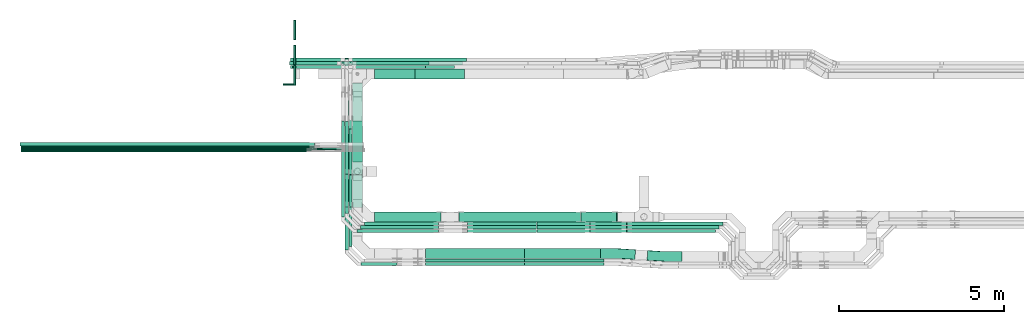
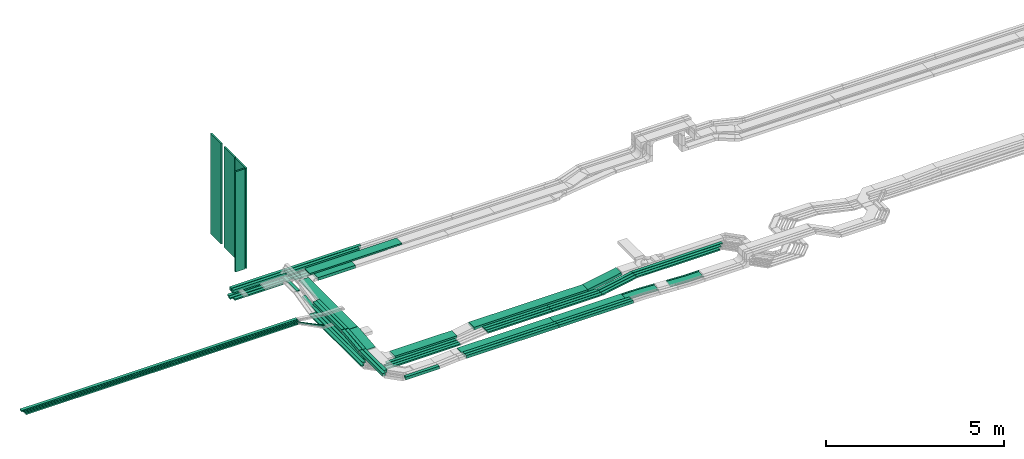
# One storey, part 1 of 32: 60 flow segments, 2 flow fittings.
"""IFC2X3 building model written with IfcOpenShell, lengths in millimetres."""

import ifcopenshell
import ifcopenshell.guid

model = None  # the IFC model being written
_history = None  # IfcOwnerHistory: only IFC2X3 demands one
_inside = {}  # id of a spatial element -> (the spatial element, [elements in it])
_under = {}  # id of a project, library or spatial element -> (it, [spatial elements below it])
_declared = {}  # id of a project -> (the project, [libraries it declares])
_typed = {}  # id of a type object -> (the type object, [elements of that type])
_made_of = {}  # id of a material, layer set ... -> (it, [elements and type objects made of it])


def new_model(schema):
    """Start an empty IFC model of exactly this schema.

    Asked for "IFC4X3", IfcOpenShell would pick the latest addendum, in which some entities
    have other attributes; the version numbers below select the first issue.
    IFC2X3 requires an IfcOwnerHistory on every rooted entity: one is made here for all.
    """
    global model, _history
    if schema == "IFC4X3":
        model = ifcopenshell.file(schema_version=(4, 3, 0, 0))
    else:
        model = ifcopenshell.file(schema=schema)
    _inside.clear()
    _under.clear()
    _declared.clear()
    _typed.clear()
    _made_of.clear()
    _history = None
    if model.schema == "IFC2X3":
        org = make("IfcOrganization", Name="unknown")
        user = make(
            "IfcPersonAndOrganization",
            ThePerson=make("IfcPerson", FamilyName="unknown"),
            TheOrganization=org,
        )
        app = make(
            "IfcApplication",
            ApplicationDeveloper=org,
            Version="unknown",
            ApplicationFullName="unknown",
            ApplicationIdentifier="unknown",
        )
        _history = make(
            "IfcOwnerHistory",
            OwningUser=user,
            OwningApplication=app,
            ChangeAction="ADDED",
            CreationDate=0,
        )
    return model


def make(cls, **values):
    """One entity of the class cls with the attributes given. An attribute that is None is left unset."""
    return model.create_entity(
        cls, **{name: value for name, value in values.items() if value is not None}
    )


def entity(cls, *values):
    """Any entity or typed value of the class cls, its attributes in the order of the schema. None: left unset."""
    e = model.create_entity(cls)
    for i, value in enumerate(values):
        if value is not None:
            e[i] = value
    return e


def rooted(cls, **values):
    """An entity with a GlobalId (a new one), such as an element, a storey or a relation."""
    return make(cls, GlobalId=ifcopenshell.guid.new(), OwnerHistory=_history, **values)


def si_unit(unit_type, name, prefix=None):
    """IfcSIUnit, for example si_unit("LENGTHUNIT", "METRE", prefix="MILLI")."""
    return make("IfcSIUnit", UnitType=unit_type, Prefix=prefix, Name=name)


def converted_unit(unit_type, name, factor, base, dimensions=None, offset=None):
    """IfcConversionBasedUnit, such as the inch: factor (a typed value) times the base unit."""
    return make(
        "IfcConversionBasedUnit"
        if offset is None
        else "IfcConversionBasedUnitWithOffset",
        ConversionOffset=offset,
        Dimensions=None
        if dimensions is None
        else entity("IfcDimensionalExponents", *dimensions),
        UnitType=unit_type,
        Name=name,
        ConversionFactor=make(
            "IfcMeasureWithUnit", ValueComponent=factor, UnitComponent=base
        ),
    )


def derived_unit(unit_type, elements):
    """IfcDerivedUnit: a product of units, each with its exponent."""
    return make(
        "IfcDerivedUnit",
        Elements=[
            make("IfcDerivedUnitElement", Unit=unit, Exponent=power)
            for unit, power in elements
        ],
        UnitType=unit_type,
    )


def assignment(units):
    """IfcUnitAssignment: the units of a project."""
    return None if units is None else make("IfcUnitAssignment", Units=units)


def point(xyz):
    """IfcCartesianPoint."""
    return None if xyz is None else make("IfcCartesianPoint", Coordinates=xyz)


def direction(xyz):
    """IfcDirection."""
    return None if xyz is None else make("IfcDirection", DirectionRatios=xyz)


def frame(location, z_axis=None, x_axis=None):
    """IfcAxis2Placement3D, a coordinate frame: its origin and axes. An axis left out is left unset."""
    return make(
        "IfcAxis2Placement3D",
        Location=point(location),
        Axis=direction(z_axis),
        RefDirection=direction(x_axis),
    )


def frame_2d(location, x_axis=None):
    """IfcAxis2Placement2D, a coordinate frame in the plane: its origin and x axis."""
    return make(
        "IfcAxis2Placement2D", Location=point(location), RefDirection=direction(x_axis)
    )


def origin():
    """The frame at (0, 0, 0) with its axes left unset."""
    return frame((0.0, 0.0, 0.0))


def origin_2d_with_axis():
    """The frame at (0, 0) in the plane with the x axis (1, 0) written out."""
    return frame_2d((0.0, 0.0), x_axis=(1.0, 0.0))


def place(relative_to, where):
    """IfcLocalPlacement: puts the frame where relative to a parent placement (None: the world)."""
    return make(
        "IfcLocalPlacement", PlacementRelTo=relative_to, RelativePlacement=where
    )


def context(
    kind, dimensions, precision=None, world=None, true_north=None, identifier=None
):
    """IfcGeometricRepresentationContext, for example the 3D "Model" context."""
    return make(
        "IfcGeometricRepresentationContext",
        ContextIdentifier=identifier,
        ContextType=kind,
        CoordinateSpaceDimension=dimensions,
        Precision=precision,
        WorldCoordinateSystem=world,
        TrueNorth=true_north,
    )


def subcontext(parent, identifier, kind, view, scale=None):
    """IfcGeometricRepresentationSubContext, for example "Body" below "Model"."""
    return make(
        "IfcGeometricRepresentationSubContext",
        ContextIdentifier=identifier,
        ContextType=kind,
        ParentContext=parent,
        TargetScale=scale,
        TargetView=view,
    )


def project(units=None, contexts=None):
    """IfcProject with its units and contexts."""
    return rooted(
        "IfcProject",
        Name="project",
        RepresentationContexts=contexts,
        UnitsInContext=assignment(units),
    )


def spatial(cls, under=None, at=None, **own):
    """A site, building, storey or space (cls), placed at a placement, below another one or the project."""
    s = rooted(cls, ObjectPlacement=at, **own)
    if under is not None:
        _under.setdefault(under.id(), (under, []))[1].append(s)
    return s


def profile(cls, at=None, kind="AREA", **sizes):
    """A parametric profile (cls). Its sizes go by their IFC names, for example OverallWidth=200.0."""
    return make(cls, ProfileType=kind, Position=at, **sizes)


def rectangle(**sizes):
    """IfcRectangleProfileDef."""
    return profile("IfcRectangleProfileDef", **sizes)


def extrude(swept, where, along, depth):
    """IfcExtrudedAreaSolid: the profile swept, set in the frame where, extruded along a direction by depth."""
    return make(
        "IfcExtrudedAreaSolid",
        SweptArea=swept,
        Position=where,
        ExtrudedDirection=direction(along),
        Depth=depth,
    )


def faces_of(points, faces, orient=None, outer=None):
    """IfcFace entities. A face is a list of loops; a loop is a list of indices into points, from 0.

    orient and outer hold one flag for each loop. By default every Orientation is true, the
    first loop of a face is its IfcFaceOuterBound and the others are IfcFaceBound.
    """
    made = []
    for i, loops in enumerate(faces):
        bounds = []
        for j, loop in enumerate(loops):
            is_outer = j == 0 if outer is None else outer[i][j]
            bounds.append(
                make(
                    "IfcFaceOuterBound" if is_outer else "IfcFaceBound",
                    Bound=make("IfcPolyLoop", Polygon=[points[k] for k in loop]),
                    Orientation=True if orient is None else orient[i][j],
                )
            )
        made.append(make("IfcFace", Bounds=bounds))
    return made


def faceted_brep(points, faces, orient=None, outer=None, voids=None):
    """IfcFacetedBrep: a solid bounded by flat faces; with voids (closed shells), ...WithVoids."""
    shared = [point(p) for p in points]
    hull = make("IfcClosedShell", CfsFaces=faces_of(shared, faces, orient, outer))
    if voids is None:
        return make("IfcFacetedBrep", Outer=hull)
    return make(
        "IfcFacetedBrepWithVoids",
        Outer=hull,
        Voids=[
            make(cls, CfsFaces=faces_of(shared, fs, o, b)) for cls, fs, o, b in voids
        ],
    )


def shape(context_of_items, identifier, shape_type, items):
    """IfcShapeRepresentation: the items that make up one representation, for example the "Body"."""
    return make(
        "IfcShapeRepresentation",
        ContextOfItems=context_of_items,
        RepresentationIdentifier=identifier,
        RepresentationType=shape_type,
        Items=items,
    )


def source(mapping_origin, context_of_items, identifier, shape_type, items):
    """IfcRepresentationMap: a shape defined once, which mapped items show again and again."""
    return make(
        "IfcRepresentationMap",
        MappingOrigin=mapping_origin,
        MappedRepresentation=shape(context_of_items, identifier, shape_type, items),
    )


def transform(
    local_origin,
    x_axis=None,
    y_axis=None,
    z_axis=None,
    scale=None,
    scale2=None,
    scale3=None,
    uniform=True,
):
    """IfcCartesianTransformationOperator3D, or its non-uniform kind. x_axis, y_axis, z_axis: its Axis1, 2, 3."""
    if uniform:
        return make(
            "IfcCartesianTransformationOperator3D",
            Axis1=direction(x_axis),
            Axis2=direction(y_axis),
            LocalOrigin=point(local_origin),
            Scale=scale,
            Axis3=direction(z_axis),
        )
    return make(
        "IfcCartesianTransformationOperator3DnonUniform",
        Axis1=direction(x_axis),
        Axis2=direction(y_axis),
        LocalOrigin=point(local_origin),
        Scale=scale,
        Axis3=direction(z_axis),
        Scale2=scale2,
        Scale3=scale3,
    )


def mapped(mapping_source, mapping_target):
    """IfcMappedItem: shows the shape of a source again, moved by a transform."""
    return make(
        "IfcMappedItem", MappingSource=mapping_source, MappingTarget=mapping_target
    )


def material(Name=None, Category=None):
    """IfcMaterial."""
    return make("IfcMaterial", Name=Name, Category=Category)


def made_of(thing, what):
    """Note that an element or type object is made of a material, layer set ...; save() writes the relation."""
    if what is not None:
        _made_of.setdefault(what.id(), (what, []))[1].append(thing)
    return thing


def type_object(cls, material=None, **own):
    """A type object (cls), such as IfcWallType, which elements share."""
    return made_of(rooted(cls, **own), material)


def type_shapes(of_type, sources):
    """Give a type object the sources (RepresentationMaps) that its elements show as mapped items."""
    of_type.RepresentationMaps = sources


def element(
    cls,
    number,
    at=None,
    inside=None,
    cuts=None,
    type_object=None,
    material=None,
    context=None,
    identifier="Body",
    shape_type=None,
    held_by="IfcProductDefinitionShape",
    body=None,
    shapes=None,
    **own,
):
    """One element of the class cls, such as IfcWall. Its Tag is "e" and its number.

    at: its placement. inside: the storey or other place that contains it. cuts: it is an
    opening in that element (IfcRelVoidsElement). A single representation is given by context,
    identifier, shape_type and body (its items); several are given by shapes. held_by: the class
    of the entity that holds the representations. save() writes the other relations.
    """
    e = rooted(cls, Tag="e%d" % number, ObjectPlacement=at, **own)
    if body is not None:
        shapes = [shape(context, identifier, shape_type, body)]
    if shapes is not None:
        e.Representation = make(held_by, Representations=shapes)
    if inside is not None:
        _inside.setdefault(inside.id(), (inside, []))[1].append(e)
    if cuts is not None:
        rooted(
            "IfcRelVoidsElement", RelatingBuildingElement=cuts, RelatedOpeningElement=e
        )
    if type_object is not None:
        _typed.setdefault(type_object.id(), (type_object, []))[1].append(e)
    return made_of(e, material)


def aggregate(whole, parts):
    """IfcRelAggregates: a whole, such as a stair, and the parts it consists of."""
    return rooted("IfcRelAggregates", RelatingObject=whole, RelatedObjects=parts)


def save(model, path):
    """Write the relations noted so far, then the file.

    IfcRelAggregates (storeys below a building ...), IfcRelContainedInSpatialStructure (elements
    in a storey), IfcRelDefinesByType, IfcRelAssociatesMaterial and IfcRelDeclares: one each for
    every whole, place, type object, material and project.
    """
    for whole, parts in _under.values():
        aggregate(whole, parts)
    for where, things in _inside.values():
        rooted(
            "IfcRelContainedInSpatialStructure",
            RelatedElements=things,
            RelatingStructure=where,
        )
    for kind, things in _typed.values():
        rooted("IfcRelDefinesByType", RelatedObjects=things, RelatingType=kind)
    for what, things in _made_of.values():
        rooted("IfcRelAssociatesMaterial", RelatedObjects=things, RelatingMaterial=what)
    for by, libraries in _declared.values():
        rooted("IfcRelDeclares", RelatingContext=by, RelatedDefinitions=libraries)
    model.write(path)


model = new_model("IFC2X3")

# Units and contexts
model_context = context("Model", 3, precision=0.01, world=origin(), true_north=direction((6.12303176911189e-17, 1.0)))
body_context = subcontext(model_context, "Body", "Model", "MODEL_VIEW")
ifc_project = project(units=[si_unit("LENGTHUNIT", "METRE", prefix="MILLI"), si_unit("AREAUNIT", "SQUARE_METRE"), si_unit("VOLUMEUNIT", "CUBIC_METRE"), converted_unit("PLANEANGLEUNIT", "DEGREE", entity("IfcRatioMeasure", 0.0174532925199433), si_unit("PLANEANGLEUNIT", "RADIAN"), dimensions=[0, 0, 0, 0, 0, 0, 0]), si_unit("MASSUNIT", "GRAM", prefix="KILO"), derived_unit("MASSDENSITYUNIT", [(si_unit("MASSUNIT", "GRAM", prefix="KILO"), 1), (si_unit("LENGTHUNIT", "METRE"), -3)]), derived_unit("MOMENTOFINERTIAUNIT", [(si_unit("LENGTHUNIT", "METRE"), 4)]), si_unit("TIMEUNIT", "SECOND"), si_unit("FREQUENCYUNIT", "HERTZ"), si_unit("THERMODYNAMICTEMPERATUREUNIT", "DEGREE_CELSIUS"), derived_unit("THERMALTRANSMITTANCEUNIT", [(si_unit("MASSUNIT", "GRAM", prefix="KILO"), 1), (si_unit("THERMODYNAMICTEMPERATUREUNIT", "KELVIN"), -1), (si_unit("TIMEUNIT", "SECOND"), -3)]), derived_unit("VOLUMETRICFLOWRATEUNIT", [(si_unit("LENGTHUNIT", "METRE"), 3), (si_unit("TIMEUNIT", "SECOND"), -1)]), derived_unit("MASSFLOWRATEUNIT", [(si_unit("MASSUNIT", "GRAM", prefix="KILO"), 1), (si_unit("TIMEUNIT", "SECOND"), -1)]), derived_unit("ROTATIONALFREQUENCYUNIT", [(si_unit("TIMEUNIT", "SECOND"), -1)]), si_unit("ELECTRICCURRENTUNIT", "AMPERE"), si_unit("ELECTRICVOLTAGEUNIT", "VOLT"), si_unit("POWERUNIT", "WATT"), si_unit("FORCEUNIT", "NEWTON", prefix="KILO"), si_unit("ILLUMINANCEUNIT", "LUX"), si_unit("LUMINOUSFLUXUNIT", "LUMEN"), si_unit("LUMINOUSINTENSITYUNIT", "CANDELA"), derived_unit("USERDEFINED", [(si_unit("MASSUNIT", "GRAM", prefix="KILO"), -1), (si_unit("LENGTHUNIT", "METRE"), -2), (si_unit("TIMEUNIT", "SECOND"), 3), (si_unit("LUMINOUSFLUXUNIT", "LUMEN"), 1)]), derived_unit("LINEARVELOCITYUNIT", [(si_unit("LENGTHUNIT", "METRE"), 1), (si_unit("TIMEUNIT", "SECOND"), -1)]), si_unit("PRESSUREUNIT", "PASCAL"), derived_unit("USERDEFINED", [(si_unit("LENGTHUNIT", "METRE"), -2), (si_unit("MASSUNIT", "GRAM", prefix="KILO"), 1), (si_unit("TIMEUNIT", "SECOND"), -2)]), derived_unit("LINEARFORCEUNIT", [(si_unit("MASSUNIT", "GRAM", prefix="KILO"), 1), (si_unit("LENGTHUNIT", "METRE"), 1), (si_unit("TIMEUNIT", "SECOND"), -2), (si_unit("LENGTHUNIT", "METRE"), -1)]), derived_unit("PLANARFORCEUNIT", [(si_unit("MASSUNIT", "GRAM", prefix="KILO"), 1), (si_unit("LENGTHUNIT", "METRE"), 1), (si_unit("TIMEUNIT", "SECOND"), -2), (si_unit("LENGTHUNIT", "METRE"), -2)])], contexts=[model_context])

# Site, building, storey
site_placement = place(None, origin())
site = spatial("IfcSite", under=ifc_project, at=site_placement, CompositionType="ELEMENT")
building_placement = place(site_placement, origin())
building = spatial("IfcBuilding", under=site, at=building_placement, CompositionType="ELEMENT")
storey_placement = place(building_placement, frame((0.0, 0.0, 8100.0)))
storey = spatial("IfcBuildingStorey", under=building, at=storey_placement, CompositionType="ELEMENT", Elevation=8100.0)

# Flow segments
cable_carrier_segment_type_1 = type_object("IfcCableCarrierSegmentType", PredefinedType="CABLETRAYSEGMENT")
flow_segment_1_placement = place(storey_placement, frame((18361.01, 14492.28, 2565.34)))
element("IfcFlowSegment", 1, at=flow_segment_1_placement, inside=storey, type_object=cable_carrier_segment_type_1, context=body_context, shape_type="SweptSolid", body=[
    extrude(rectangle(XDim=2981.2300000051, YDim=99.9999999999989, at=origin_2d_with_axis()), frame((1490.62, 50.0, 0.0)), (0.0, 0.0, 1.0), 50.0000000000016),
])
flow_segment_2_placement = place(storey_placement, frame((16421.3, 14492.28, 2565.34)))
element("IfcFlowSegment", 2, at=flow_segment_2_placement, inside=storey, type_object=cable_carrier_segment_type_1, context=body_context, shape_type="SweptSolid", body=[
    extrude(rectangle(XDim=1579.7076946329, YDim=99.9999999999989, at=origin_2d_with_axis()), frame((789.85, 50.0, 0.0), z_axis=(0.0, 0.0, 1.0), x_axis=(-1.0, 0.0, 0.0)), (0.0, 0.0, 1.0), 50.0000000000016),
])
flow_segment_3_placement = place(storey_placement, frame((16331.51, 14602.28, 2570.0)))
element("IfcFlowSegment", 3, at=flow_segment_3_placement, inside=storey, type_object=cable_carrier_segment_type_1, context=body_context, shape_type="SweptSolid", body=[
    extrude(rectangle(XDim=1629.50675573799, YDim=99.9999999999989, at=origin_2d_with_axis()), frame((814.75, 50.0, 0.0), z_axis=(0.0, 0.0, 1.0), x_axis=(-1.0, 0.0, 0.0)), (0.0, 0.0, 1.0), 50.0000000000016),
])
flow_segment_4_placement = place(storey_placement, frame((18676.05, 14182.28, 2840.02)))
element("IfcFlowSegment", 4, at=flow_segment_4_placement, inside=storey, type_object=cable_carrier_segment_type_1, context=body_context, shape_type="SweptSolid", body=[
    extrude(rectangle(XDim=2971.23000000509, YDim=300.000000000001, at=origin_2d_with_axis()), frame((1485.62, 150.0, 0.0)), (0.0, 0.0, 1.0), 50.0000000000016),
])
flow_segment_5_placement = place(storey_placement, frame((18076.05, 14492.28, 2840.0)))
element("IfcFlowSegment", 5, at=flow_segment_5_placement, inside=storey, type_object=cable_carrier_segment_type_1, context=body_context, shape_type="SweptSolid", body=[
    extrude(rectangle(XDim=2385.50742869904, YDim=99.9999999999989, at=origin_2d_with_axis()), frame((1192.75, 50.0, 0.0), z_axis=(0.0, 0.0, 1.0), x_axis=(-1.0, 0.0, 0.0)), (0.0, 0.0, 1.0), 99.9999999999989),
])
flow_segment_6_placement = place(storey_placement, frame((18186.05, 14602.28, 2840.0)))
element("IfcFlowSegment", 6, at=flow_segment_6_placement, inside=storey, type_object=cable_carrier_segment_type_1, context=body_context, shape_type="SweptSolid", body=[
    extrude(rectangle(XDim=2385.50742869902, YDim=99.9999999999989, at=origin_2d_with_axis()), frame((1192.75, 50.0, 0.0), z_axis=(0.0, 0.0, 1.0), x_axis=(-1.0, 0.0, 0.0)), (0.0, 0.0, 1.0), 99.9999999999989),
])
flow_segment_7_placement = place(storey_placement, frame((18922.05, 9845.0, 2500.0)))
element("IfcFlowSegment", 7, at=flow_segment_7_placement, inside=storey, type_object=cable_carrier_segment_type_1, context=body_context, shape_type="SweptSolid", body=[
    extrude(rectangle(XDim=2011.88022352649, YDim=300.000000000001, at=origin_2d_with_axis()), frame((1005.94, 150.0, 0.0)), (0.0, 0.0, 1.0), 99.9999999999989),
])
flow_segment_8_placement = place(storey_placement, frame((23464.79, 8622.45, 2789.67)))
element("IfcFlowSegment", 8, at=flow_segment_8_placement, inside=storey, type_object=cable_carrier_segment_type_1, context=body_context, shape_type="SweptSolid", body=[
    extrude(rectangle(XDim=2411.83602414101, YDim=100.000000000001, at=origin_2d_with_axis()), frame((1205.92, 50.0, 0.0)), (0.0, 0.0, 1.0), 99.9999999999989),
])
flow_segment_9_placement = place(storey_placement, frame((23462.62, 8732.05, 2790.02)))
element("IfcFlowSegment", 9, at=flow_segment_9_placement, inside=storey, type_object=cable_carrier_segment_type_1, context=body_context, shape_type="SweptSolid", body=[
    extrude(rectangle(XDim=2314.00000000008, YDim=299.999999999999, at=origin_2d_with_axis()), frame((1157.0, 150.0, 0.0)), (0.0, 0.0, 1.0), 50.0000000000016),
])
flow_segment_10_placement = place(storey_placement, frame((23468.94, 8512.45, 2789.32)))
element("IfcFlowSegment", 10, at=flow_segment_10_placement, inside=storey, type_object=cable_carrier_segment_type_1, context=body_context, shape_type="SweptSolid", body=[
    extrude(rectangle(XDim=2407.68395125738, YDim=99.9999999999989, at=origin_2d_with_axis()), frame((1203.84, 50.0, 0.0)), (0.0, 0.0, 1.0), 99.9999999999989),
])
flow_segment_11_placement = place(storey_placement, frame((18246.05, 11278.23, 2840.02)))
element("IfcFlowSegment", 11, at=flow_segment_11_placement, inside=storey, type_object=cable_carrier_segment_type_1, context=body_context, shape_type="SweptSolid", body=[
    extrude(rectangle(XDim=2774.04434845544, YDim=299.999999999997, at=origin_2d_with_axis()), frame((150.0, 1387.02, 0.0), z_axis=(0.0, -6.46277580620266e-07, 1.0), x_axis=(0.0, -1.0, -6.46277580620266e-07)), (0.0, 0.0, 1.0), 49.9999999999991),
])
flow_segment_12_placement = place(storey_placement, frame((18246.05, 11656.25, 2500.0)))
element("IfcFlowSegment", 12, at=flow_segment_12_placement, inside=storey, type_object=cable_carrier_segment_type_1, context=body_context, shape_type="SweptSolid", body=[
    extrude(rectangle(XDim=1245.36492297945, YDim=300.000000000001, at=origin_2d_with_axis()), frame((150.0, 622.68, 0.0), z_axis=(0.0, 0.0, 1.0), x_axis=(0.0, -1.0, 0.0)), (0.0, 0.0, 1.0), 99.9999999999989),
])
flow_segment_13_placement = place(storey_placement, frame((16359.58, 14712.28, 2570.0)))
element("IfcFlowSegment", 13, at=flow_segment_13_placement, inside=storey, type_object=cable_carrier_segment_type_1, context=body_context, shape_type="SweptSolid", body=[
    extrude(rectangle(XDim=1711.42940224653, YDim=99.9999999999989, at=origin_2d_with_axis()), frame((855.71, 50.0, 0.0), z_axis=(0.0, 0.0, 1.0), x_axis=(-1.0, 0.0, 0.0)), (0.0, 0.0, 1.0), 49.9999999999995),
])
flow_segment_14_placement = place(storey_placement, frame((23838.88, 9735.0, 2589.16)))
element("IfcFlowSegment", 14, at=flow_segment_14_placement, inside=storey, type_object=cable_carrier_segment_type_1, context=body_context, shape_type="SweptSolid", body=[
    extrude(rectangle(XDim=1615.92542255297, YDim=99.9999999999989, at=origin_2d_with_axis()), frame((807.96, 50.0, 0.0)), (0.0, 0.0, 1.0), 50.0000000000016),
])
flow_segment_15_placement = place(storey_placement, frame((23838.88, 9625.48, 2590.43)))
element("IfcFlowSegment", 15, at=flow_segment_15_placement, inside=storey, type_object=cable_carrier_segment_type_1, context=body_context, shape_type="SweptSolid", body=[
    extrude(rectangle(XDim=1615.94124469224, YDim=99.9999999999989, at=origin_2d_with_axis()), frame((807.97, 50.0, 0.0)), (0.0, 0.0, 1.0), 50.0000000000016),
])
flow_segment_16_placement = place(storey_placement, frame((23838.88, 9515.48, 2590.49)))
element("IfcFlowSegment", 16, at=flow_segment_16_placement, inside=storey, type_object=cable_carrier_segment_type_1, context=body_context, shape_type="SweptSolid", body=[
    extrude(rectangle(XDim=1615.94353988623, YDim=100.000000000001, at=origin_2d_with_axis()), frame((807.97, 50.0, 0.0)), (0.0, 0.0, 1.0), 50.0000000000016),
])
flow_segment_17_placement = place(storey_placement, frame((26574.44, 9735.0, 2800.0)))
element("IfcFlowSegment", 17, at=flow_segment_17_placement, inside=storey, type_object=cable_carrier_segment_type_1, context=body_context, shape_type="SweptSolid", body=[
    extrude(rectangle(XDim=2911.03097819719, YDim=99.9999999999989, at=origin_2d_with_axis()), frame((1455.52, 50.0, 0.0)), (0.0, 0.0, 1.0), 50.0000000000016),
])
flow_segment_18_placement = place(storey_placement, frame((26574.26, 9625.48, 2800.0)))
element("IfcFlowSegment", 18, at=flow_segment_18_placement, inside=storey, type_object=cable_carrier_segment_type_1, context=body_context, shape_type="SweptSolid", body=[
    extrude(rectangle(XDim=2801.68153191295, YDim=99.9999999999989, at=origin_2d_with_axis()), frame((1400.84, 50.0, 0.0)), (0.0, 0.0, 1.0), 50.0000000000016),
])
flow_segment_19_placement = place(storey_placement, frame((21484.25, 9845.0, 2595.02)))
element("IfcFlowSegment", 19, at=flow_segment_19_placement, inside=storey, type_object=cable_carrier_segment_type_1, context=body_context, shape_type="SweptSolid", body=[
    extrude(rectangle(XDim=3688.2870636457, YDim=300.000000000001, at=origin_2d_with_axis()), frame((1844.14, 150.0, 0.0)), (0.0, 0.0, 1.0), 99.9999999999989),
])
flow_segment_20_placement = place(storey_placement, frame((18502.05, 8512.45, 2739.32)))
element("IfcFlowSegment", 20, at=flow_segment_20_placement, inside=storey, type_object=cable_carrier_segment_type_1, context=body_context, shape_type="SweptSolid", body=[
    extrude(rectangle(XDim=1090.93059039301, YDim=100.000000000001, at=origin_2d_with_axis()), frame((545.47, 50.0, 0.0), z_axis=(0.0, 0.0, 1.0), x_axis=(-1.0, 0.0, 0.0)), (0.0, 0.0, 1.0), 100.000000000001),
])
flow_segment_21_placement = place(storey_placement, frame((8199.58, 12091.75, 3060.0)))
element("IfcFlowSegment", 21, at=flow_segment_21_placement, inside=storey, type_object=cable_carrier_segment_type_1, context=body_context, shape_type="SweptSolid", body=[
    extrude(rectangle(XDim=8897.16239513093, YDim=50.0000000000016, at=origin_2d_with_axis()), frame((4448.58, 25.0, 0.0), z_axis=(0.0, 0.0, 1.0), x_axis=(-1.0, 0.0, 0.0)), (0.0, 0.0, 1.0), 50.0000000000016),
])
flow_segment_22_placement = place(storey_placement, frame((18922.05, 14174.5, 2565.0)))
element("IfcFlowSegment", 22, at=flow_segment_22_placement, inside=storey, type_object=cable_carrier_segment_type_1, context=body_context, shape_type="SweptSolid", body=[
    extrude(rectangle(XDim=1223.84496020994, YDim=300.000000000001, at=origin_2d_with_axis()), frame((611.92, 150.0, 0.0), z_axis=(0.0, 0.0, 1.0), x_axis=(-1.0, 0.0, 0.0)), (0.0, 0.0, 1.0), 99.9999999999989),
])
flow_segment_23_placement = place(storey_placement, frame((20462.62, 8732.05, 2790.02)))
element("IfcFlowSegment", 23, at=flow_segment_23_placement, inside=storey, type_object=cable_carrier_segment_type_1, context=body_context, shape_type="SweptSolid", body=[
    extrude(rectangle(XDim=2997.46000001016, YDim=299.999999999999, at=origin_2d_with_axis()), frame((1498.73, 150.0, 0.0), z_axis=(0.0, 0.0, 1.0), x_axis=(-1.0, 0.0, 0.0)), (0.0, 0.0, 1.0), 50.0000000000016),
])
flow_segment_24_placement = place(storey_placement, frame((8199.58, 12031.75, 3060.0)))
element("IfcFlowSegment", 24, at=flow_segment_24_placement, inside=storey, type_object=cable_carrier_segment_type_1, context=body_context, shape_type="SweptSolid", body=[
    extrude(rectangle(XDim=8812.29056112652, YDim=50.0000000000016, at=origin_2d_with_axis()), frame((4406.15, 25.0, 0.0), z_axis=(0.0, 0.0, 1.0), x_axis=(-1.0, 0.0, 0.0)), (0.0, 0.0, 1.0), 50.0000000000016),
])
flow_segment_25_placement = place(storey_placement, frame((8199.58, 11971.75, 3060.0)))
element("IfcFlowSegment", 25, at=flow_segment_25_placement, inside=storey, type_object=cable_carrier_segment_type_1, context=body_context, shape_type="SweptSolid", body=[
    extrude(rectangle(XDim=8811.8645785195, YDim=50.0000000000016, at=origin_2d_with_axis()), frame((4405.93, 25.0, 0.0), z_axis=(0.0, 0.0, 1.0), x_axis=(-1.0, 0.0, 0.0)), (0.0, 0.0, 1.0), 50.0000000000016),
])
flow_segment_26_placement = place(storey_placement, frame((20464.79, 8622.45, 2789.67)))
element("IfcFlowSegment", 26, at=flow_segment_26_placement, inside=storey, type_object=cable_carrier_segment_type_1, context=body_context, shape_type="SweptSolid", body=[
    extrude(rectangle(XDim=2997.46000001016, YDim=100.000000000001, at=origin_2d_with_axis()), frame((1498.73, 50.0, 0.0), z_axis=(0.0, 0.0, 1.0), x_axis=(-1.0, 0.0, 0.0)), (0.0, 0.0, 1.0), 99.9999999999989),
])
flow_segment_27_placement = place(storey_placement, frame((20468.94, 8512.45, 2789.32)))
element("IfcFlowSegment", 27, at=flow_segment_27_placement, inside=storey, type_object=cable_carrier_segment_type_1, context=body_context, shape_type="SweptSolid", body=[
    extrude(rectangle(XDim=2997.46000001016, YDim=99.9999999999989, at=origin_2d_with_axis()), frame((1498.73, 50.0, 0.0), z_axis=(0.0, 0.0, 1.0), x_axis=(-1.0, 0.0, 0.0)), (0.0, 0.0, 1.0), 99.9999999999989),
])
flow_segment_28_placement = place(storey_placement, frame((8159.58, 12151.75, 3060.0)))
element("IfcFlowSegment", 28, at=flow_segment_28_placement, inside=storey, type_object=cable_carrier_segment_type_1, context=body_context, shape_type="SweptSolid", body=[
    extrude(rectangle(XDim=8936.98769079436, YDim=99.9999999999989, at=origin_2d_with_axis()), frame((4468.49, 50.0, 0.0), z_axis=(0.0, 0.0, 1.0), x_axis=(-1.0, 0.0, 0.0)), (0.0, 0.0, 1.0), 50.0000000000016),
])
flow_segment_29_placement = place(storey_placement, frame((18607.01, 9735.0, 2495.32)))
element("IfcFlowSegment", 29, at=flow_segment_29_placement, inside=storey, type_object=cable_carrier_segment_type_1, context=body_context, shape_type="SweptSolid", body=[
    extrude(rectangle(XDim=2253.98527272605, YDim=99.9999999999989, at=origin_2d_with_axis()), frame((1126.99, 50.0, 0.0), z_axis=(0.0, 0.0, 1.0), x_axis=(-1.0, 0.0, 0.0)), (0.0, 0.0, 1.0), 50.0000000000016),
])
flow_segment_30_placement = place(storey_placement, frame((18497.01, 9625.48, 2495.47)))
element("IfcFlowSegment", 30, at=flow_segment_30_placement, inside=storey, type_object=cable_carrier_segment_type_1, context=body_context, shape_type="SweptSolid", body=[
    extrude(rectangle(XDim=2363.95663058173, YDim=99.9999999999989, at=origin_2d_with_axis()), frame((1181.98, 50.0, 0.0), z_axis=(0.0, 0.0, 1.0), x_axis=(-1.0, 0.0, 0.0)), (0.0, 0.0, 1.0), 50.0000000000016),
])
flow_segment_31_placement = place(storey_placement, frame((18387.01, 9515.48, 2500.0)))
element("IfcFlowSegment", 31, at=flow_segment_31_placement, inside=storey, type_object=cable_carrier_segment_type_1, context=body_context, shape_type="SweptSolid", body=[
    extrude(rectangle(XDim=2473.54052636319, YDim=100.000000000001, at=origin_2d_with_axis()), frame((1236.77, 50.0, 0.0), z_axis=(0.0, 0.0, 1.0), x_axis=(-1.0, 0.0, 0.0)), (0.0, 0.0, 1.0), 50.0000000000016),
])
flow_segment_32_placement = place(storey_placement, frame((18131.01, 12665.28, 2495.52)))
element("IfcFlowSegment", 32, at=flow_segment_32_placement, inside=storey, type_object=cable_carrier_segment_type_1, context=body_context, shape_type="SweptSolid", body=[
    extrude(rectangle(XDim=49.9999999999999, YDim=1019.51076030492, at=frame_2d((0.0, 0.0), x_axis=(0.0, 1.0))), frame((0.0, 510.27, 59.82), z_axis=(1.0, 0.0, 0.0), x_axis=(0.0, 0.997656992775831, 0.0684143608132536)), (0.0, 0.0, 1.0), 99.9999999999989),
])
flow_segment_33_placement = place(storey_placement, frame((18021.01, 13788.82, 2710.72)))
element("IfcFlowSegment", 33, at=flow_segment_33_placement, inside=storey, type_object=cable_carrier_segment_type_1, context=body_context, shape_type="SweptSolid", body=[
    extrude(rectangle(XDim=1004.45523850221, YDim=99.9999999999989, at=origin_2d_with_axis()), frame((50.0, 502.23, 0.0), z_axis=(0.0, 0.0, 1.0), x_axis=(0.0, 1.0, 0.0)), (0.0, 0.0, 1.0), 50.0000000000038),
])
flow_segment_34_placement = place(storey_placement, frame((18072.01, 14712.28, 2570.0)))
element("IfcFlowSegment", 34, at=flow_segment_34_placement, inside=storey, type_object=cable_carrier_segment_type_1, context=body_context, shape_type="SweptSolid", body=[
    extrude(rectangle(XDim=3635.06094064414, YDim=99.9999999999989, at=origin_2d_with_axis()), frame((1817.53, 50.0, 0.0), z_axis=(0.0, 0.0, 1.0), x_axis=(-1.0, 0.0, 0.0)), (0.0, 0.0, 1.0), 50.0000000000016),
])
flow_segment_35_placement = place(storey_placement, frame((17962.01, 14602.28, 2570.0)))
element("IfcFlowSegment", 35, at=flow_segment_35_placement, inside=storey, type_object=cable_carrier_segment_type_1, context=body_context, shape_type="SweptSolid", body=[
    extrude(rectangle(XDim=3629.49324426201, YDim=99.9999999999989, at=origin_2d_with_axis()), frame((1814.75, 50.0, 0.0), z_axis=(0.0, 0.0, 1.0), x_axis=(-1.0, 0.0, 0.0)), (0.0, 0.0, 1.0), 50.0000000000016),
])
flow_segment_36_placement = place(storey_placement, frame((18136.05, 11279.53, 2840.0)))
element("IfcFlowSegment", 36, at=flow_segment_36_placement, inside=storey, type_object=cable_carrier_segment_type_1, context=body_context, shape_type="SweptSolid", body=[
    extrude(rectangle(XDim=1630.30438948267, YDim=99.9999999999989, at=origin_2d_with_axis()), frame((50.0, 815.15, 0.0), z_axis=(0.0, 0.0, 1.0), x_axis=(0.0, 1.0, 0.0)), (0.0, 0.0, 1.0), 99.9999999999989),
])
flow_segment_37_placement = place(storey_placement, frame((18026.05, 11299.51, 2840.0)))
element("IfcFlowSegment", 37, at=flow_segment_37_placement, inside=storey, type_object=cable_carrier_segment_type_1, context=body_context, shape_type="SweptSolid", body=[
    extrude(rectangle(XDim=1589.99978553911, YDim=99.9999999999989, at=origin_2d_with_axis()), frame((50.0, 795.0, 0.0), z_axis=(0.0, 0.0, 1.0), x_axis=(0.0, 1.0, 0.0)), (0.0, 0.0, 1.0), 99.9999999999989),
])
flow_segment_38_placement = place(storey_placement, frame((18136.05, 9098.45, 2739.54)))
element("IfcFlowSegment", 38, at=flow_segment_38_placement, inside=storey, type_object=cable_carrier_segment_type_1, context=body_context, shape_type="SweptSolid", body=[
    extrude(rectangle(XDim=1190.24865025856, YDim=99.9999999999989, at=origin_2d_with_axis()), frame((50.0, 595.12, 0.0), z_axis=(0.0, 0.0, 1.0), x_axis=(0.0, -1.0, 0.0)), (0.0, 0.0, 1.0), 99.9999999999968),
])
flow_segment_39_placement = place(storey_placement, frame((18026.05, 8988.45, 2739.32)))
element("IfcFlowSegment", 39, at=flow_segment_39_placement, inside=storey, type_object=cable_carrier_segment_type_1, context=body_context, shape_type="SweptSolid", body=[
    extrude(rectangle(XDim=1310.27046438656, YDim=99.9999999999989, at=origin_2d_with_axis()), frame((50.0, 655.14, 0.0), z_axis=(0.0, 0.0, 1.0), x_axis=(0.0, -1.0, 0.0)), (0.0, 0.0, 1.0), 99.9999999999989),
])
flow_segment_40_placement = place(storey_placement, frame((18026.05, 10301.12, 2739.95)))
element("IfcFlowSegment", 40, at=flow_segment_40_placement, inside=storey, type_object=cable_carrier_segment_type_1, context=body_context, shape_type="SweptSolid", body=[
    extrude(rectangle(XDim=100.000000000002, YDim=99.9999999999989, at=origin_2d_with_axis()), frame((50.0, 5.04, 49.75), z_axis=(0.0, 0.994903033239733, 0.100836275468594), x_axis=(0.0, -0.100836275468594, 0.994903033239733)), (0.0, 0.0, 1.0), 990.956233595495),
])
flow_segment_41_placement = place(storey_placement, frame((18136.05, 10291.1, 2740.18)))
element("IfcFlowSegment", 41, at=flow_segment_41_placement, inside=storey, type_object=cable_carrier_segment_type_1, context=body_context, shape_type="SweptSolid", body=[
    extrude(rectangle(XDim=99.9999999999988, YDim=980.942427474035, at=frame_2d((0.0, 0.0), x_axis=(0.0, 1.0))), frame((0.0, 493.01, 99.59), z_axis=(1.0, 0.0, 0.0), x_axis=(0.0, 0.994821450765378, 0.101637990422228)), (0.0, 0.0, 1.0), 100.000000000001),
])
flow_segment_42_placement = place(storey_placement, frame((18246.05, 10281.99, 2740.39)))
element("IfcFlowSegment", 42, at=flow_segment_42_placement, inside=storey, type_object=cable_carrier_segment_type_1, context=body_context, shape_type="SweptSolid", body=[
    extrude(rectangle(XDim=50.0000000000003, YDim=993.839659670533, at=frame_2d((0.0, 0.0), x_axis=(0.0, 1.0))), frame((0.0, 496.93, 74.63), z_axis=(1.0, 0.0, 0.0), x_axis=(0.0, 0.994974854702739, 0.100125114278404)), (0.0, 0.0, 1.0), 300.000000000001),
])
flow_segment_43_placement = place(storey_placement, frame((16359.58, 14492.28, 2840.0)))
element("IfcFlowSegment", 43, at=flow_segment_43_placement, inside=storey, type_object=cable_carrier_segment_type_1, context=body_context, shape_type="SweptSolid", body=[
    extrude(rectangle(XDim=1715.46940223623, YDim=99.9999999999989, at=origin_2d_with_axis()), frame((857.73, 50.0, 0.0), z_axis=(0.0, 0.0, 1.0), x_axis=(-1.0, 0.0, 0.0)), (0.0, 0.0, 1.0), 99.9999999999989),
])
flow_segment_44_placement = place(storey_placement, frame((16359.58, 14602.28, 2840.0)))
element("IfcFlowSegment", 44, at=flow_segment_44_placement, inside=storey, type_object=cable_carrier_segment_type_1, context=body_context, shape_type="SweptSolid", body=[
    extrude(rectangle(XDim=1825.46940223625, YDim=99.9999999999989, at=origin_2d_with_axis()), frame((912.73, 50.0, 0.0), z_axis=(0.0, 0.0, 1.0), x_axis=(-1.0, 0.0, 0.0)), (0.0, 0.0, 1.0), 99.9999999999989),
])
flow_segment_45_placement = place(storey_placement, frame((18021.01, 10101.48, 2495.47)))
element("IfcFlowSegment", 45, at=flow_segment_45_placement, inside=storey, type_object=cable_carrier_segment_type_1, context=body_context, shape_type="SweptSolid", body=[
    extrude(rectangle(XDim=2799.02544525247, YDim=99.9999999999989, at=origin_2d_with_axis()), frame((50.0, 1399.51, 0.0), z_axis=(0.0, 0.0, 1.0), x_axis=(0.0, 1.0, 0.0)), (0.0, 0.0, 1.0), 50.0000000000016),
])
flow_segment_46_placement = place(storey_placement, frame((17911.01, 9991.48, 2500.0)))
element("IfcFlowSegment", 46, at=flow_segment_46_placement, inside=storey, type_object=cable_carrier_segment_type_1, context=body_context, shape_type="SweptSolid", body=[
    extrude(rectangle(XDim=2909.02544525244, YDim=99.9999999999989, at=origin_2d_with_axis()), frame((50.0, 1454.51, 0.0), z_axis=(0.0, 0.0, 1.0), x_axis=(0.0, 1.0, 0.0)), (0.0, 0.0, 1.0), 50.0000000000016),
])
flow_segment_47_placement = place(storey_placement, frame((18131.01, 10211.0, 2495.32)))
element("IfcFlowSegment", 47, at=flow_segment_47_placement, inside=storey, type_object=cable_carrier_segment_type_1, context=body_context, shape_type="SweptSolid", body=[
    extrude(rectangle(XDim=2452.00682826396, YDim=99.9999999999989, at=origin_2d_with_axis()), frame((50.0, 1226.0, 0.0), z_axis=(0.0, 0.0, 1.0), x_axis=(0.0, 1.0, 0.0)), (0.0, 0.0, 1.0), 50.0000000000016),
])
flow_segment_48_placement = place(storey_placement, frame((21742.17, 9515.48, 2590.49)))
element("IfcFlowSegment", 48, at=flow_segment_48_placement, inside=storey, type_object=cable_carrier_segment_type_1, context=body_context, shape_type="SweptSolid", body=[
    extrude(rectangle(XDim=2094.1693501488, YDim=100.000000000001, at=origin_2d_with_axis()), frame((1047.08, 50.0, 0.0)), (0.0, 0.0, 1.0), 50.0000000000016),
])
flow_segment_49_placement = place(storey_placement, frame((21741.44, 9625.48, 2590.43)))
element("IfcFlowSegment", 49, at=flow_segment_49_placement, inside=storey, type_object=cable_carrier_segment_type_1, context=body_context, shape_type="SweptSolid", body=[
    extrude(rectangle(XDim=2094.8915245106, YDim=99.9999999999989, at=origin_2d_with_axis()), frame((1047.45, 50.0, 0.0)), (0.0, 0.0, 1.0), 50.0000000000016),
])
flow_segment_50_placement = place(storey_placement, frame((21741.65, 9735.0, 2589.16)))
element("IfcFlowSegment", 50, at=flow_segment_50_placement, inside=storey, type_object=cable_carrier_segment_type_1, context=body_context, shape_type="SweptSolid", body=[
    extrude(rectangle(XDim=2094.68442613129, YDim=99.9999999999989, at=origin_2d_with_axis()), frame((1047.34, 50.0, 0.0)), (0.0, 0.0, 1.0), 50.0000000000016),
])
flow_segment_51_placement = place(storey_placement, frame((25457.54, 9515.48, 2591.61)))
element("IfcFlowSegment", 51, at=flow_segment_51_placement, inside=storey, type_object=cable_carrier_segment_type_1, context=body_context, shape_type="SweptSolid", body=[
    extrude(rectangle(XDim=49.9999999999993, YDim=99.9999999999989, at=origin_2d_with_axis()), frame((4.63, 50.0, 24.57), z_axis=(0.982730588994872, 0.0, 0.185042128862028), x_axis=(-0.185042128862028, 0.0, 0.982730588994872)), (0.0, 0.0, 1.0), 1124.80210120938),
])
flow_segment_52_placement = place(storey_placement, frame((25457.54, 9625.48, 2591.55)))
element("IfcFlowSegment", 52, at=flow_segment_52_placement, inside=storey, type_object=cable_carrier_segment_type_1, context=body_context, shape_type="SweptSolid", body=[
    extrude(rectangle(XDim=50.0000000000024, YDim=100.000000000001, at=origin_2d_with_axis()), frame((4.63, 50.0, 24.57), z_axis=(0.982701539841543, 0.0, 0.18519633795802), x_axis=(-0.18519633795802, 0.0, 0.982701539841543)), (0.0, 0.0, 1.0), 1124.18632336721),
])
flow_segment_53_placement = place(storey_placement, frame((25457.53, 9735.0, 2590.29)))
element("IfcFlowSegment", 53, at=flow_segment_53_placement, inside=storey, type_object=cable_carrier_segment_type_1, context=body_context, shape_type="SweptSolid", body=[
    extrude(rectangle(XDim=50.0000000000009, YDim=99.9999999999989, at=origin_2d_with_axis()), frame((4.66, 50.0, 24.56), z_axis=(0.982500640063244, 0.0, 0.186259207222934), x_axis=(-0.186259207222934, 0.0, 0.982500640063244)), (0.0, 0.0, 1.0), 1124.54697135174),
])
flow_segment_54_placement = place(storey_placement, frame((25175.25, 9845.0, 2596.96)))
element("IfcFlowSegment", 54, at=flow_segment_54_placement, inside=storey, type_object=cable_carrier_segment_type_1, context=body_context, shape_type="SweptSolid", body=[
    extrude(rectangle(XDim=99.999999999999, YDim=300.000000000001, at=origin_2d_with_axis()), frame((9.16, 150.0, 49.15), z_axis=(0.983076107251635, 0.0, 0.183197618300492), x_axis=(-0.183197618300492, 0.0, 0.983076107251635)), (0.0, 0.0, 1.0), 1106.93960876275),
])
flow_segment_55_placement = place(storey_placement, frame((26574.89, 9515.48, 2800.0)))
element("IfcFlowSegment", 55, at=flow_segment_55_placement, inside=storey, type_object=cable_carrier_segment_type_1, context=body_context, shape_type="SweptSolid", body=[
    extrude(rectangle(XDim=2691.05032236578, YDim=99.9999999999989, at=origin_2d_with_axis()), frame((1345.53, 50.0, 0.0)), (0.0, 0.0, 1.0), 50.0000000000016),
])
flow_segment_56_placement = place(storey_placement, frame((17015.53, 12031.75, 2625.93)))
element("IfcFlowSegment", 56, at=flow_segment_56_placement, inside=storey, type_object=cable_carrier_segment_type_1, context=body_context, shape_type="SweptSolid", body=[
    extrude(rectangle(XDim=50.000000000001, YDim=50.0000000000016, at=origin_2d_with_axis()), frame((10.98, 25.0, 455.69), z_axis=(0.898384360919167, 0.0, -0.439210132005013), x_axis=(0.439210132005013, 0.0, 0.898384360919167)), (0.0, 0.0, 1.0), 986.379505162213),
])
cable_carrier_segment_type_2 = type_object("IfcCableCarrierSegmentType", PredefinedType="CABLETRAYSEGMENT")
flow_segment_57_placement = place(storey_placement, frame((16472.31, 15367.61, 3945.84)))
element("IfcFlowSegment", 57, at=flow_segment_57_placement, inside=storey, type_object=cable_carrier_segment_type_2, context=body_context, shape_type="SweptSolid", body=[
    extrude(rectangle(XDim=50.0000000000016, YDim=600.000000000002, at=origin_2d_with_axis()), frame((25.0, 300.0, 0.0), z_axis=(0.0, 0.0, 1.0), x_axis=(-1.0, 0.0, 0.0)), (0.0, 0.0, 1.0), 3440.0),
])
flow_segment_58_placement = place(storey_placement, frame((16472.31, 14607.61, 3945.84)))
element("IfcFlowSegment", 58, at=flow_segment_58_placement, inside=storey, type_object=cable_carrier_segment_type_2, context=body_context, shape_type="SweptSolid", body=[
    extrude(rectangle(XDim=50.0000000000016, YDim=599.999999999998, at=origin_2d_with_axis()), frame((25.0, 300.0, 0.0), z_axis=(0.0, 0.0, 1.0), x_axis=(-1.0, 0.0, 0.0)), (0.0, 0.0, 1.0), 3440.0),
])
flow_segment_59_placement = place(storey_placement, frame((16472.31, 13987.61, 3945.84)))
element("IfcFlowSegment", 59, at=flow_segment_59_placement, inside=storey, type_object=cable_carrier_segment_type_2, context=body_context, shape_type="SweptSolid", body=[
    extrude(rectangle(XDim=50.0000000000016, YDim=600.000000000002, at=origin_2d_with_axis()), frame((25.0, 300.0, 0.0), z_axis=(0.0, 0.0, 1.0), x_axis=(-1.0, 0.0, 0.0)), (0.0, 0.0, 1.0), 3440.0),
])
flow_segment_60_placement = place(storey_placement, frame((16147.31, 13982.61, 3945.84)))
element("IfcFlowSegment", 60, at=flow_segment_60_placement, inside=storey, type_object=cable_carrier_segment_type_2, context=body_context, shape_type="SweptSolid", body=[
    extrude(rectangle(XDim=50.0000000000016, YDim=300.000000000001, at=origin_2d_with_axis()), frame((150.0, 25.0, 0.0), z_axis=(0.0, 0.0, 1.0), x_axis=(0.0, 1.0, 0.0)), (0.0, 0.0, 1.0), 3435.0),
])

# Flow fittings
ifc_material = material()
cable_carrier_fitting_type = type_object("IfcCableCarrierFittingType", Name="470_DKC_G5_Sheet horizontal bend:-", PredefinedType="NOTDEFINED", material=ifc_material)
shared_shape = source(origin(), body_context, "Body", "Brep", [
    faceted_brep([(-526.0, -150.0, -25.0), (-526.0, -150.0, 25.0), (-526.0, -145.0, 25.0), (-526.0, -145.0, -20.0), (-526.0, 145.0, -20.0), (-526.0, 145.0, 25.0), (-526.0, 150.0, 25.0), (-526.0, 150.0, -25.0), (4.76, -150.0, -25.0), (4.76, -150.0, 25.0), (534.45, -116.35, 25.0), (534.13, -111.36, 25.0), (4.6, -145.0, 25.0), (4.6, -145.0, -20.0), (534.13, -111.36, -20.0), (515.75, 178.05, -20.0), (-4.6, 145.0, -20.0), (-4.6, 145.0, 25.0), (515.75, 178.05, 25.0), (515.43, 183.04, 25.0), (-4.76, 150.0, 25.0), (-4.76, 150.0, -25.0), (515.43, 183.04, -25.0), (534.45, -116.35, -25.0)], [[[0, 1, 2, 3, 4, 5, 6, 7]], [[1, 0, 8, 9]], [[2, 1, 9, 10, 11, 12]], [[3, 2, 12, 13]], [[4, 3, 13, 14, 15, 16]], [[5, 4, 16, 17]], [[6, 5, 17, 18, 19, 20]], [[7, 6, 20, 21]], [[8, 0, 7, 21, 22, 23]], [[23, 22, 19, 18, 15, 14, 11, 10]], [[9, 8, 23, 10]], [[13, 12, 11, 14]], [[17, 16, 15, 18]], [[21, 20, 19, 22]]]),
])
type_shapes(cable_carrier_fitting_type, [shared_shape])
for number, where, z_axis, x_axis, name in (
    (61, (26302.62, 8882.05, 2815.02), (0.0, 0.0, 1.0), (-0.997988582354139, 0.0633939231375997, 0.0), "470_DKC_G5_Sheet horizontal bend:-"),
    (62, (27719.46, 8792.05, 2815.02), (0.0, 0.0, 1.0), (0.997988582354136, -0.0633939231376403, 0.0), "470_DKC_G5_Sheet horizontal bend:-"),
):
    element("IfcFlowFitting", number, at=place(storey_placement, frame(where, z_axis=z_axis, x_axis=x_axis)), inside=storey, type_object=cable_carrier_fitting_type, material=ifc_material, Name=name, ObjectType="470_DKC_G5_Sheet horizontal bend:-", context=body_context, shape_type="MappedRepresentation", body=[
        mapped(shared_shape, transform((0.0, 0.0, 0.0), scale=1.0)),
    ])

save(model, "model.ifc")
